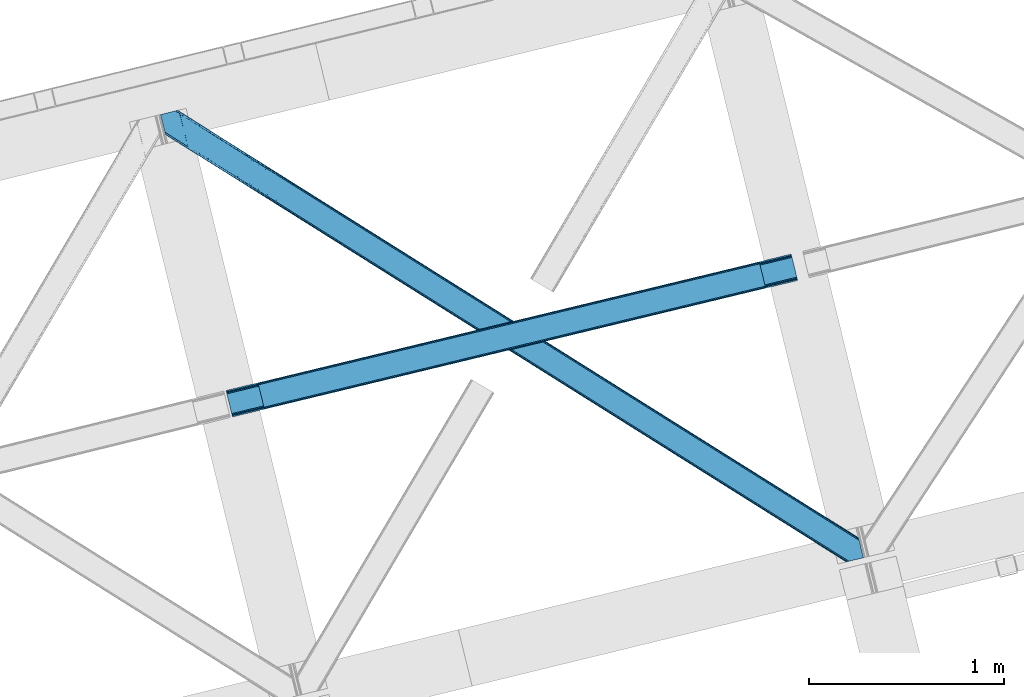
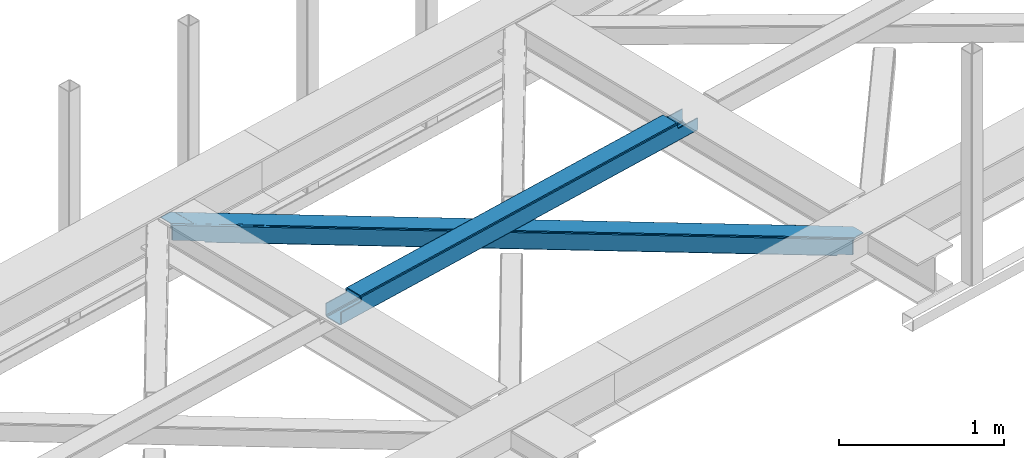
# One storey, part 24 of 67: 1 beam, 1 member.
"""IFC4 building model written with IfcOpenShell, lengths in millimetres."""

from ifc_helpers import new_model, entity, si_unit, converted_unit, derived_unit, direction, frame, origin, place, context, subcontext, project, spatial, triangles, polygons, material, type_object, element, save


model = new_model("IFC4")

# Units and contexts
model_context = context("Model", 3, precision=0.01, world=origin(), true_north=direction((6.12303176911189e-17, 1.0)))
plan_context = context("Plan", 3, precision=0.01, world=origin(), true_north=direction((6.12303176911189e-17, 1.0)))
body_context = subcontext(model_context, "Body", "Model", "MODEL_VIEW")
ifc_project = project(units=[si_unit("LENGTHUNIT", "METRE", prefix="MILLI"), si_unit("AREAUNIT", "SQUARE_METRE"), si_unit("VOLUMEUNIT", "CUBIC_METRE"), converted_unit("PLANEANGLEUNIT", "DEGREE", entity("IfcRatioMeasure", 0.0174532925199433), si_unit("PLANEANGLEUNIT", "RADIAN"), dimensions=[0, 0, 0, 0, 0, 0, 0]), si_unit("MASSUNIT", "GRAM", prefix="KILO"), derived_unit("MASSDENSITYUNIT", [(si_unit("MASSUNIT", "GRAM", prefix="KILO"), 1), (si_unit("LENGTHUNIT", "METRE"), -3)]), derived_unit("MOMENTOFINERTIAUNIT", [(si_unit("LENGTHUNIT", "METRE"), 4)]), si_unit("TIMEUNIT", "SECOND"), si_unit("FREQUENCYUNIT", "HERTZ"), si_unit("THERMODYNAMICTEMPERATUREUNIT", "DEGREE_CELSIUS"), derived_unit("THERMALTRANSMITTANCEUNIT", [(si_unit("MASSUNIT", "GRAM", prefix="KILO"), 1), (si_unit("THERMODYNAMICTEMPERATUREUNIT", "KELVIN"), -1), (si_unit("TIMEUNIT", "SECOND"), -3)]), derived_unit("VOLUMETRICFLOWRATEUNIT", [(si_unit("LENGTHUNIT", "METRE"), 3), (si_unit("TIMEUNIT", "SECOND"), -1)]), derived_unit("MASSFLOWRATEUNIT", [(si_unit("MASSUNIT", "GRAM", prefix="KILO"), 1), (si_unit("TIMEUNIT", "SECOND"), -1)]), derived_unit("ROTATIONALFREQUENCYUNIT", [(si_unit("TIMEUNIT", "SECOND"), -1)]), si_unit("ELECTRICCURRENTUNIT", "AMPERE"), si_unit("ELECTRICVOLTAGEUNIT", "VOLT"), si_unit("POWERUNIT", "WATT"), si_unit("FORCEUNIT", "NEWTON", prefix="KILO"), si_unit("ILLUMINANCEUNIT", "LUX"), si_unit("LUMINOUSFLUXUNIT", "LUMEN"), si_unit("LUMINOUSINTENSITYUNIT", "CANDELA"), derived_unit("USERDEFINED", [(si_unit("MASSUNIT", "GRAM", prefix="KILO"), -1), (si_unit("LENGTHUNIT", "METRE"), -2), (si_unit("TIMEUNIT", "SECOND"), 3), (si_unit("LUMINOUSFLUXUNIT", "LUMEN"), 1)]), derived_unit("LINEARVELOCITYUNIT", [(si_unit("LENGTHUNIT", "METRE"), 1), (si_unit("TIMEUNIT", "SECOND"), -1)]), si_unit("PRESSUREUNIT", "PASCAL"), derived_unit("USERDEFINED", [(si_unit("LENGTHUNIT", "METRE"), -2), (si_unit("MASSUNIT", "GRAM", prefix="KILO"), 1), (si_unit("TIMEUNIT", "SECOND"), -2)]), derived_unit("LINEARFORCEUNIT", [(si_unit("MASSUNIT", "GRAM", prefix="KILO"), 1), (si_unit("LENGTHUNIT", "METRE"), 1), (si_unit("TIMEUNIT", "SECOND"), -2), (si_unit("LENGTHUNIT", "METRE"), -1)]), derived_unit("PLANARFORCEUNIT", [(si_unit("MASSUNIT", "GRAM", prefix="KILO"), 1), (si_unit("LENGTHUNIT", "METRE"), 1), (si_unit("TIMEUNIT", "SECOND"), -2), (si_unit("LENGTHUNIT", "METRE"), -2)])], contexts=[model_context, plan_context])

# Site, building, storey
site_placement = place(None, origin())
site = spatial("IfcSite", under=ifc_project, at=site_placement, CompositionType="ELEMENT")
building_placement = place(site_placement, origin())
building = spatial("IfcBuilding", under=site, at=building_placement, CompositionType="ELEMENT")
storey_placement = place(building_placement, frame((0.0, 0.0, 19800.0)))
storey = spatial("IfcBuildingStorey", under=building, at=storey_placement, CompositionType="ELEMENT", Elevation=19800.0)

# Beam
ifc_material = material(Name="Metal painted (White)")
beam_type = type_object("IfcBeamType", PredefinedType="BEAM")
beam_placement = place(storey_placement, frame((-51911.0997216183, 6486.04890050032, 3967.02210387248)))
element("IfcBeam", 1, at=beam_placement, inside=storey, type_object=beam_type, material=ifc_material, ObjectType="Steel Beam", PredefinedType="BEAM", context=body_context, shape_type="Tessellation", body=[
    polygons([(195.778682216866, 46.4616874765742, 115.554291398401), (195.463203470787, 47.7559030808816, 122.251250865174), (2771.46289360968, 669.656122833178, 123.101189027514), (2771.77837235578, 668.361907228809, 116.404229560714), (194.564796011733, 51.4415173004408, 127.928657073123), (2770.56448615062, 673.341737052787, 128.778595235445), (193.220234231301, 56.9574287804367, 131.722176392876), (2769.21992437018, 678.85764853278, 132.572114555207), (191.634215472016, 63.4638900000246, 133.054279896355), (2767.63390561093, 685.364109752213, 133.904218058669), (170.082988398813, 151.875343121848, 133.054215405194), (2746.08267853773, 773.775562874038, 133.904153567521), (168.496969639606, 158.381804341166, 131.72210240954), (2744.49665977849, 780.28202409347, 132.572040571853), (167.152407859165, 163.897715821159, 127.928575042685), (2743.15209799806, 785.797935573463, 128.778513205003), (166.254000400103, 167.583330040754, 122.251163457846), (2742.25369053899, 789.483549793037, 123.101101620168), (165.938521653972, 168.877545645258, 115.554202102942), (2741.93821179289, 790.777765397476, 116.404140265269), (2740.28042509495, 797.578646406835, 101.477896127514), (2740.28042509495, 797.578646406844, 123.40413566445), (2740.59590384104, 796.284430802519, 130.101097019346), (2741.49431130009, 792.598816582945, 135.778508604176), (2742.83887308054, 787.082905102956, 139.572035971027), (2744.4248918398, 780.576443883409, 140.904148966698), (2769.29169230888, 678.563228742844, 140.904223379569), (2770.87771106808, 672.056767523566, 139.572119876094), (2772.22227284852, 666.540856043575, 135.778600556341), (2773.12068030758, 662.855241823993, 130.101194348401), (2773.43615905372, 661.561026219421, 123.404234881614), (2773.43615905373, 661.561026219411, 101.477896127514), (2771.77837235579, 668.361907228782, 101.477896127514), (2741.9382117929, 790.777765397463, 101.477896127514), (165.938521653972, 168.877545645274, 100.498120018943), (195.778682216866, 46.4616874765926, 100.498120018943), (197.436468914803, 39.6608064672213, 100.498120018943), (197.436468914803, 39.6608064672115, 122.554296719296), (197.120990168698, 40.9550220716445, 129.251256186074), (196.222582709644, 44.6406362912287, 134.928662394019), (194.878020929195, 50.1565477712202, 138.722181713772), (193.292002169953, 56.6630089906522, 140.054285217251), (168.425201700885, 158.676224131221, 140.054210804376), (166.839182941635, 165.182685350655, 138.722097808709), (165.494621161203, 170.698596830647, 134.928570441863), (164.59621370214, 174.384211050237, 129.251158857028), (164.280734956026, 175.67842665464, 122.554197502128), (164.280734956035, 175.678426654645, 100.498120018943), (2936.05910731181, 708.022713695996, 100.477896127497), (2936.0591073118, 708.022713695992, 25.4584284837512), (31.4979472608401, 6.80088100936265, 24.5000831143001), (31.4979472608314, 6.80088100937781, 99.4981200189255), (194.806606862087, 46.2270081483837, 99.4981200189385), (1.657786697954, 129.216739178047, 24.4999938188589), (2906.21894674892, 830.438571864674, 25.4583391883013), (2906.21894674892, 830.438571864675, 100.477896127506), (2742.91028714767, 791.012444725669, 100.477896127515), (1.65778669794533, 129.216739178059, 99.4981200189342), (2937.71689400975, 701.221832686621, 18.4584330845693), (2937.71689400975, 701.221832686624, 100.477896127497), (2774.40823440849, 661.795705547618, 100.477896127515), (33.1557339587681, 6.49720277579036e-12, 99.4981200189298), (33.1557339587768, 4.33146851719357e-12, 17.5000877151226), (2904.56116005097, 837.239452874047, 100.477896127506), (2904.56116005097, 837.239452874045, 18.4583338674014), (0.0, 136.017620187427, 17.499988497959), (0.0, 136.017620187429, 99.4981200189342), (163.308659601255, 175.443747326438, 99.4981200189428), (2772.75044771055, 668.596586556989, 100.477896127506), (2741.25250044972, 797.81332573504, 100.47789612751), (2906.53442549502, 829.144356260237, 18.7613797215148), (2907.43283295407, 825.458742040662, 13.0839735135745), (2908.77739473452, 819.942830560673, 9.29045419381724), (2910.36341349377, 813.436369341239, 7.95835069034235), (2931.91464056696, 725.024916219415, 7.95841518150347), (2933.50065932619, 718.518454999981, 9.29052817716638), (2934.84522110663, 713.002543519989, 13.0840555440168), (2935.7436285657, 709.316929300409, 18.7614671288472), (2937.40141526367, 702.516048290886, 11.761471729687), (2936.50300780461, 706.20166251046, 6.08406014484364), (2935.15844602418, 711.717573990453, 2.29053277800185), (2933.5724272649, 718.224035210042, 0.958419782317287), (2908.70562679582, 820.237250350608, 0.958345369446738), (2907.1196080366, 826.743711569928, 2.29044887293462), (2905.77504625616, 832.259623049922, 6.0839681926919), (2904.87663879711, 835.945237269508, 11.7613744006322), (196.464393560023, 39.4261271390135, 99.4981200189342), (164.966446299201, 168.642866317066, 99.4981200189385), (27.3534805159897, 23.803083532798, 7.00006981205673), (28.9394992752661, 17.2966223132111, 8.33218280774563), (30.2840610557156, 11.7807108332185, 12.1257101745917), (31.1824685147694, 8.09509661364405, 17.8031217594308), (1.97326544407667, 127.922523573537, 17.8030343520854), (2.87167290313907, 124.236909353931, 12.1256281441494), (4.21623468357996, 118.72099787394, 8.33210882439216), (5.80225344279568, 112.214536654621, 7.00000532091294), (0.315478746122676, 134.723404583003, 10.8030290311768), (1.21388620517641, 131.037790363419, 5.12562282323216), (2.5584479856173, 125.521878883426, 1.33210350348355), (4.14446674485034, 119.015417663994, 0.0), (29.0112672139351, 17.0022025234256, 7.44128792121046e-05), (30.5972859731681, 10.4957413039946, 1.33218740854212), (31.9418477536177, 4.97982982400309, 5.12571477538823), (32.8402552126714, 1.29421560440701, 10.803126360223)], [[[1, 2, 3, 4]], [[2, 5, 6, 3]], [[5, 7, 8, 6]], [[7, 9, 10, 8]], [[11, 12, 10, 9]], [[11, 13, 14, 12]], [[13, 15, 16, 14]], [[15, 17, 18, 16]], [[17, 19, 20, 18]], [[21, 22, 23, 24, 25, 26, 27, 28, 29, 30, 31, 32, 33, 4, 3, 6, 8, 10, 12, 14, 16, 18, 20, 34]], [[35, 19, 17, 15, 13, 11, 9, 7, 5, 2, 1, 36, 37, 38, 39, 40, 41, 42, 43, 44, 45, 46, 47, 48]], [[42, 41, 28, 27]], [[41, 40, 29, 28]], [[40, 39, 30, 29]], [[39, 38, 31, 30]], [[27, 26, 43, 42]], [[47, 46, 23, 22]], [[46, 45, 24, 23]], [[45, 44, 25, 24]], [[44, 43, 26, 25]], [[33, 49, 50, 51, 52, 53, 1, 4]], [[54, 55, 56, 57, 20, 19, 35, 58]], [[59, 60, 61, 31, 38, 37, 62, 63]], [[64, 65, 66, 67, 68, 47, 22, 21]], [[61, 60, 49, 69]], [[64, 70, 57, 56]], [[65, 64, 56, 55, 71, 72, 73, 74, 75, 76, 77, 78, 50, 49, 60, 59, 79, 80, 81, 82, 83, 84, 85, 86]], [[87, 53, 52, 62]], [[67, 58, 88, 68]], [[89, 90, 76, 75]], [[90, 91, 77, 76]], [[91, 92, 78, 77]], [[92, 51, 50, 78]], [[54, 93, 71, 55]], [[93, 94, 72, 71]], [[94, 95, 73, 72]], [[95, 96, 74, 73]], [[89, 75, 74, 96]], [[66, 97, 98, 99, 100, 101, 102, 103, 104, 63, 62, 52, 51, 92, 91, 90, 89, 96, 95, 94, 93, 54, 58, 67]], [[63, 104, 79, 59]], [[104, 103, 80, 79]], [[103, 102, 81, 80]], [[102, 101, 82, 81]], [[100, 99, 84, 83]], [[99, 98, 85, 84]], [[98, 97, 86, 85]], [[97, 66, 65, 86]], [[83, 82, 101, 100]]], closed=False),
])

# Member
member_type = type_object("IfcMemberType", PredefinedType="BRACE")
member_placement = place(storey_placement, frame((-52247.5317993164, 5740.77633361816, 3823.99987792968)))
element("IfcMember", 2, at=member_placement, inside=storey, type_object=member_type, ObjectType="Steel Horizontal Brace", PredefinedType="BRACE", context=body_context, shape_type="Tessellation", body=[
    triangles([(207.717553710936, 2101.81589355469, 0.0), (172.040661621089, 2248.17905273438, 0.0), (3404.48986816406, 219.29300994873, 0.0), (3440.1667602539, 72.9298507690428, 0.0), (202.587634277341, 2097.1307144165, 1.33247680664135), (208.508203124999, 2098.57423095703, 0.155804443358647), (3442.44104003906, 63.5949554443359, 1.33247680664135), (3445.65944824219, 50.3934356689451, 10.8039916992202), (3446.115234375, 48.5365722656252, 17.5012573242202), (187.946667480464, 2093.56290893555, 17.5012573242202), (189.755859375, 2094.00241699219, 10.8039916992202), (3444.37115478516, 55.6809036254881, 5.12526855468968), (194.895080566406, 2095.25582885742, 5.12526855468968), (3405.08983154297, 238.005239868164, 10.8039916992202), (3400.22036132812, 236.818103027344, 5.32758178711083), (167.836267089842, 2265.42799987793, 5.12526855468968), (166.547973632813, 2270.71546783447, 10.8039916992202), (3400.29477539063, 236.497192382813, 5.1694519042976), (3402.2155883789, 228.627905273437, 1.33247680664135), (169.766381835936, 2257.51394805908, 1.33247680664135), (3406.89437255859, 238.445329284668, 17.5012573242202), (166.092187499999, 2272.57233123779, 17.5012573242202), (3401.18774414063, 237.054716491699, 18.5197998046897), (3406.89437255859, 238.445329284668, 18.5197998046897), (3400.50406494141, 236.887284851075, 18.2267944335945), (3400.82032470703, 236.964024353028, 18.4453857421868), (3400.29012451172, 236.836125183106, 17.9035583496116), (3400.22036132812, 236.818103027344, 17.5198608398459), (3402.03885498047, 231.950958251953, 18.4453857421868), (3401.8388671875, 231.936424255371, 18.1454040527351), (3401.62027587891, 231.919564819336, 17.8198425292976), (3401.61097412109, 231.919564819336, 17.8058898925774), (3401.41563720703, 231.905030822754, 17.5198608398459), (3402.49464111328, 231.698066711426, 18.5197998046897), (3586.90198974609, 125.462109375, 18.5197998046897), (3589.63670654297, 114.236050415039, 18.5197998046897), (204.378222656247, 2097.56731567383, 12.1248413085959), (208.508203124999, 2098.57423095703, 9.69243164062573), (199.648278808592, 2096.41447906494, 17.9802978515618), (198.420446777345, 2096.11566009522, 19.5011352539077), (187.946667480464, 2093.56290893555, 19.5011352539077), (25.3054321289019, 2195.64679412842, 19.5011352539077), (22.6823364257798, 2206.42113647461, 19.5011352539077), (3437.79016113281, 82.6873947143558, 6.99957275390625), (3404.5921875, 218.870361328125, 8.3320495605476), (3402.6620727539, 226.784413146973, 12.1248413085959), (3406.86646728515, 209.535466003418, 6.99957275390625), (3443.24099121094, 60.3178298950197, 17.5198608398459), (3441.99455566406, 65.4384475708011, 12.1248413085959), (3446.115234375, 48.5365722656252, 17.5198608398459), (3440.06444091797, 73.3524993896481, 8.3320495605476), (1232.85963134765, 1574.07833862305, 6.99957275390625), (640.584155273435, 1945.82715911865, 6.99957275390625), (602.800415039063, 1862.10203704834, 6.99957275390625), (1195.07589111328, 1490.35496063232, 6.99957275390625), (1825.13510742188, 1202.32893676758, 6.99957275390625), (1787.3467163086, 1118.60730285645, 6.99957275390625), (205.340954589839, 2111.5734375, 6.99957275390625), (174.417260742186, 2238.42150878906, 6.99957275390625), (2971.89301757812, 375.112568664551, 6.99957275390625), (3009.68605957031, 458.831295776367, 6.99957275390625), (2379.62219238281, 746.86022644043, 6.99957275390625), (2417.41058349609, 830.580116271973, 6.99957275390625), (168.831555175777, 2261.33638916016, 18.501196289064), (166.092187499999, 2272.57233123779, 18.501196289064), (168.966430664063, 2260.78526000977, 17.8803039550803), (170.212866210939, 2255.67045593262, 12.1248413085959), (172.142980957033, 2247.75640411377, 8.3320495605476), (207.559423828126, 2102.47631835938, 8.8831787109375), (3444.59439697266, 58.9993057250977, 18.5197998046897), (3447.32911376953, 47.7738281250004, 18.5197998046897), (3447.04075927734, 47.9540496826176, 18.2849304199226), (3444.26883544922, 59.3173095703123, 18.2802795410171), (3446.71984863281, 48.1552001953123, 18.0198303222678), (3443.91536865234, 59.6585678100582, 18.0198303222678), (3446.39893798828, 48.3557693481443, 17.757055664064), (3443.62701416016, 59.9416900634769, 17.8058898925774), (3443.56655273437, 60.0004074096678, 17.7617065429695), (3534.35635986328, 2.65972137451172, 18.5197998046897), (3523.44074707031, 0.0, 18.5197998046897), (2962.59125976562, 360.290217590332, 24.5008300781265), (2963.29819335938, 361.418637084961, 17.8035644531265), (3532.92854003906, 2.31148681640661, 24.5008300781265), (2965.31667480469, 364.631813049316, 12.1248413085959), (596.224072265621, 1851.62128143311, 12.1248413085959), (599.242492675781, 1856.42970886231, 8.3320495605476), (594.205590820311, 1848.40810546875, 17.8035644531265), (593.498657226563, 1847.28026733398, 24.5008300781265), (22.9288330078125, 2205.40433807373, 24.5008300781265), (2968.33509521484, 369.440240478516, 8.3320495605476), (2370.3157836914, 732.037875366211, 24.5008300781265), (2371.02271728515, 733.165713500976, 17.8035644531265), (1778.0449584961, 1103.78495178223, 24.5008300781265), (1778.75189208984, 1104.91337127686, 17.8035644531265), (1185.76948242187, 1475.53260955811, 24.5008300781265), (1186.47641601563, 1476.66102905273, 17.8035644531265), (2373.04119873047, 736.379470825195, 12.1248413085959), (1780.77037353515, 1108.12654724121, 12.1248413085959), (1188.49489746094, 1479.87420501709, 12.1248413085959), (2376.05961914062, 741.187898254395, 8.3320495605476), (1783.78879394531, 1112.93555603027, 8.3320495605476), (1191.51331787109, 1484.68263244629, 8.3320495605476), (2965.14924316406, 350.42105255127, 122.499499511719), (2371.32037353516, 723.143650817871, 122.499499511719), (3523.44074707031, 0.0, 122.499499511719), (1777.49615478516, 1095.86624908447, 122.499499511719), (1183.66728515625, 1468.58826599121, 122.499499511719), (589.838415527345, 1841.31144561768, 122.499499511719), (25.3054321289019, 2195.64679412842, 122.499499511719), (3532.92854003906, 2.31148681640661, 115.499926757813), (22.9288330078125, 2205.40433807373, 115.499926757813), (3534.73308105468, 2.75157623291034, 122.197192382813), (22.4776977539077, 2207.26120147705, 122.197192382813), (3539.87230224609, 4.00440673828143, 127.873590087893), (21.1847534179688, 2212.54866943359, 127.873590087893), (3547.56485595703, 5.87929229736346, 131.668707275392), (19.2592895507769, 2220.46272125244, 131.668707275392), (3556.63872070312, 8.09136657714862, 133.001184082033), (16.9803588867144, 2229.79819793701, 133.001184082033), (3525.24993896484, 0.439508056640989, 129.196765136719), (3530.38916015625, 1.69291992187482, 134.87548828125), (3547.15092773437, 5.77929840087927, 140.00075683594), (3612.207421875, 21.6376327514645, 140.00075683594), (3612.207421875, 21.6376327514645, 133.001184082033), (3538.08171386718, 3.56780548095685, 138.668280029298), (168.515295410158, 2261.63055725098, 18.7407165527366), (165.808483886714, 2272.75313415527, 18.7360656738274), (168.171130371091, 2261.94856109619, 19.0011657714858), (165.487573242186, 2272.95428466797, 19.0011657714858), (167.822314453122, 2262.26656494141, 19.2592895507805), (165.166662597658, 2273.1548538208, 19.2639404296897), (167.506054687496, 2262.56073303223, 19.5011352539077), (164.878308105464, 2273.33565673828, 19.5011352539077), (78.2928955078096, 2318.55673370361, 19.5011352539077), (88.7666748046831, 2321.10948486328, 19.5011352539077), (649.178979492186, 1959.52109069824, 17.8035644531265), (3018.28088378906, 472.524645996094, 17.8035644531265), (3016.26705322265, 469.312051391602, 12.1248413085959), (3018.99246826172, 473.653065490723, 24.5008300781265), (3589.27858886719, 115.704565429687, 24.5008300781265), (649.885913085935, 1960.64951019287, 24.5008300781265), (79.2788818359331, 2318.79741668701, 24.5008300781265), (3013.2486328125, 464.503042602539, 8.3320495605476), (644.142077636716, 1951.49948730469, 8.3320495605476), (647.160498046876, 1956.30849609375, 12.1248413085959), (2420.97315673828, 836.252444458008, 8.3320495605476), (1828.69768066406, 1208.00126495361, 8.3320495605476), (1236.41755371093, 1579.75066680908, 8.3320495605476), (2423.99157714844, 841.060871887207, 12.1248413085959), (1831.71610107422, 1212.81027374268, 12.1248413085959), (1239.440625, 1584.55909423828, 12.1248413085959), (2426.00540771485, 844.274047851563, 17.8035644531265), (1833.72993164062, 1216.02344970703, 17.8035644531265), (1241.4544555664, 1587.77227020264, 17.8035644531265), (2426.7169921875, 845.402467346192, 24.5008300781265), (1834.43686523438, 1217.1512878418, 24.5008300781265), (1242.16138916015, 1588.90068969727, 24.5008300781265), (1247.70523681641, 1593.6864440918, 122.499499511719), (653.811254882814, 1966.45031890869, 122.499499511719), (1841.59921875, 1220.9225692749, 122.499499511719), (3586.90198974609, 125.462109375, 122.499499511719), (2435.4932006836, 848.158113098145, 122.499499511719), (3029.38253173828, 475.39423828125, 122.499499511719), (88.7666748046831, 2321.10948486328, 122.499499511719), (3591.02266845703, 108.559652709961, 127.873590087893), (3588.64141845703, 118.317196655274, 134.87548828125), (3590.57153320313, 110.403144836426, 138.668280029298), (3592.94813232421, 100.646182250976, 131.668707275392), (3595.22706298828, 91.3107055664059, 133.001184082033), (3592.84581298828, 101.068249511719, 140.00075683594), (3589.72972412109, 113.847702026367, 122.197192382813), (3587.353125, 123.605245971679, 129.196765136719), (3589.27858886719, 115.704565429687, 115.499926757813), (55.5687011718765, 2313.01753692627, 133.001184082033), (0.0, 2299.47127075195, 133.001184082033), (79.2788818359331, 2318.79741668701, 115.499926757813), (64.6425659179658, 2315.22961120605, 131.668707275392), (72.3351196289077, 2317.10449676514, 127.873590087893), (77.474340820314, 2318.35732727051, 122.197192382813), (86.962133789064, 2320.66939544678, 129.196765136719), (81.8182617187485, 2319.41656494141, 134.87548828125), (76.0604736328096, 2318.01258087158, 138.000878906252), (0.0, 2299.47127075195, 138.000878906252), (24.8542968749971, 2197.50365753174, 129.196765136719), (23.5660034179673, 2202.79170684814, 134.87548828125), (22.1195800781206, 2208.71634521484, 138.000878906252), (98.1893554687485, 2304.12331237793, 138.000878906252), (139.386840820313, 2135.11211700439, 138.000878906252), (599.144824218747, 1856.13321533203, 140.00075683594), (139.824023437497, 2137.54568939209, 139.000817871096), (140.051916503908, 2136.3818069458, 138.668280029298), (137.842749023439, 2145.67368164063, 140.00075683594), (592.563830566403, 1845.6524597168, 134.87548828125), (139.805419921875, 2135.0249130249, 138.075292968751), (595.582250976564, 1850.460887146, 138.668280029298), (139.917041015622, 2135.65917663574, 138.352020263672), (140.033312988278, 2136.29576568604, 138.631072998047), (2974.45100097656, 365.243403625488, 140.00075683594), (2970.88842773438, 359.570494079589, 138.668280029298), (2967.87000732421, 354.762066650391, 134.87548828125), (2965.85617675781, 351.548890686036, 129.196765136719), (590.549999999996, 1842.43928375244, 129.196765136719), (2372.0273071289, 724.271488952637, 129.196765136719), (1778.2030883789, 1096.99408721924, 129.196765136719), (1184.37421875, 1469.71668548584, 129.196765136719), (2374.04578857421, 727.484664916992, 134.87548828125), (1780.21691894531, 1100.20726318359, 134.87548828125), (1186.39270019531, 1472.92986145019, 134.87548828125), (2377.06420898438, 732.293092346192, 138.668280029298), (1783.23533935547, 1105.01627197266, 138.668280029298), (1189.41112060547, 1477.73828887939, 138.668280029298), (2380.62213134766, 737.965420532227, 140.00075683594), (1786.79791259766, 1110.68801879883, 140.00075683594), (1192.96904296875, 1483.41061706543, 140.00075683594), (651.085839843749, 1962.10930480957, 134.87548828125), (98.7056030273452, 2303.62683105469, 138.075292968751), (99.1985961914033, 2302.47515716553, 138.384576416018), (648.067419433595, 1957.30029602051, 138.668280029298), (99.5985717773438, 2301.53742370606, 138.633398437501), (644.509497070314, 1951.62796783447, 140.00075683594), (100.184582519527, 2300.16425170898, 139.000817871096), (102.165856933592, 2292.03625946045, 140.00075683594), (3028.67559814453, 474.265818786621, 129.196765136719), (3026.65711669921, 471.052642822266, 134.87548828125), (3023.64334716797, 466.244215393066, 138.668280029298), (3020.08077392578, 460.571887207031, 140.00075683594), (653.104321289058, 1965.32189941406, 129.196765136719), (2426.18679199219, 833.335762023926, 140.00075683594), (2429.74936523438, 839.008090209961, 138.668280029298), (1832.2974609375, 1206.10021820068, 140.00075683594), (1835.85538330078, 1211.77196502686, 138.668280029298), (1238.40347900391, 1578.86409301758, 140.00075683594), (1241.96140136719, 1584.53642120361, 138.668280029298), (2432.76778564453, 843.817098999023, 134.87548828125), (1838.87380371094, 1216.58097381592, 134.87548828125), (1244.97982177734, 1589.34484863281, 134.87548828125), (2434.78161621094, 847.030274963379, 129.196765136719), (1840.89228515625, 1219.79414978027, 129.196765136719), (1246.99830322265, 1592.55802459717, 129.196765136719)], [[1, 2, 3], [3, 4, 1], [5, 6, 4], [4, 7, 5], [8, 9, 10], [10, 11, 8], [12, 8, 11], [11, 13, 12], [7, 12, 13], [13, 5, 7], [6, 1, 4], [14, 15, 16], [16, 17, 14], [18, 19, 20], [19, 3, 2], [2, 20, 19], [20, 16, 18], [15, 18, 16], [21, 14, 17], [17, 22, 21], [23, 21, 24], [25, 23, 26], [23, 25, 27], [23, 27, 28], [21, 23, 28], [28, 15, 14], [14, 21, 28], [26, 29, 30], [25, 30, 31], [27, 32, 33], [27, 31, 32], [33, 28, 27], [31, 27, 25], [30, 25, 26], [23, 34, 29], [29, 26, 23], [34, 24, 35], [24, 34, 23], [35, 36, 34], [37, 38, 5], [37, 5, 13], [13, 11, 39], [38, 6, 5], [39, 37, 13], [11, 10, 40], [41, 40, 10], [11, 40, 39], [42, 43, 40], [40, 41, 42], [3, 44, 4], [45, 19, 46], [33, 15, 28], [18, 33, 46], [33, 18, 15], [3, 19, 45], [46, 19, 18], [3, 47, 44], [45, 47, 3], [8, 48, 9], [48, 12, 49], [12, 48, 8], [50, 9, 48], [49, 7, 51], [51, 4, 44], [4, 51, 7], [49, 12, 7], [52, 53, 54], [54, 55, 52], [55, 56, 52], [56, 55, 57], [53, 58, 54], [53, 59, 58], [60, 61, 62], [61, 60, 47], [44, 47, 60], [63, 62, 61], [57, 63, 56], [62, 63, 57], [17, 22, 64], [22, 65, 64], [66, 17, 64], [66, 16, 17], [67, 16, 66], [20, 67, 68], [67, 20, 16], [2, 20, 68], [68, 59, 2], [69, 38, 6], [69, 1, 58], [1, 59, 58], [59, 1, 2], [69, 6, 1], [70, 71, 72], [72, 73, 70], [73, 72, 74], [74, 75, 73], [75, 76, 77], [75, 74, 76], [76, 78, 77], [78, 76, 50], [50, 48, 78], [71, 70, 79], [79, 80, 71], [81, 70, 73], [73, 82, 81], [73, 75, 82], [75, 77, 82], [83, 79, 70], [70, 81, 83], [82, 77, 78], [78, 84, 82], [78, 48, 84], [48, 49, 84], [54, 58, 69], [85, 86, 38], [86, 69, 38], [87, 85, 37], [88, 87, 39], [39, 40, 88], [88, 40, 89], [43, 89, 40], [37, 39, 87], [38, 37, 85], [69, 86, 54], [51, 44, 90], [60, 90, 44], [49, 51, 84], [90, 84, 51], [81, 82, 91], [92, 91, 82], [91, 92, 93], [94, 93, 92], [93, 94, 95], [96, 95, 94], [95, 96, 87], [87, 88, 95], [82, 84, 97], [97, 92, 82], [92, 97, 98], [98, 94, 92], [94, 98, 99], [99, 96, 94], [96, 99, 85], [85, 87, 96], [84, 90, 100], [100, 97, 84], [97, 100, 101], [101, 98, 97], [98, 101, 102], [102, 99, 98], [99, 102, 86], [86, 85, 99], [90, 60, 100], [62, 100, 60], [100, 62, 57], [57, 101, 100], [101, 57, 55], [55, 102, 101], [102, 55, 54], [54, 86, 102], [9, 103, 104], [71, 105, 72], [71, 80, 105], [105, 74, 72], [50, 105, 103], [50, 76, 105], [76, 74, 105], [9, 50, 103], [106, 10, 9], [10, 107, 108], [109, 41, 108], [106, 107, 10], [106, 9, 104], [10, 108, 41], [42, 41, 109], [81, 110, 83], [110, 81, 91], [110, 93, 111], [93, 110, 91], [88, 89, 111], [95, 111, 93], [111, 95, 88], [112, 110, 111], [111, 113, 112], [114, 112, 113], [113, 115, 114], [116, 114, 115], [115, 117, 116], [118, 116, 117], [117, 119, 118], [112, 120, 121], [118, 122, 123], [123, 124, 118], [118, 116, 122], [116, 125, 122], [114, 125, 116], [121, 125, 114], [112, 105, 120], [110, 105, 112], [121, 114, 112], [80, 83, 79], [110, 80, 105], [83, 80, 110], [65, 64, 126], [126, 127, 65], [127, 126, 128], [128, 129, 127], [129, 128, 130], [130, 131, 129], [131, 130, 132], [132, 133, 131], [134, 135, 133], [133, 132, 134], [136, 66, 67], [137, 138, 33], [138, 46, 33], [139, 29, 34], [34, 140, 139], [34, 36, 140], [139, 137, 32], [32, 31, 139], [30, 29, 139], [139, 31, 30], [141, 130, 128], [141, 132, 130], [128, 136, 141], [64, 136, 126], [128, 126, 136], [64, 66, 136], [132, 141, 142], [142, 134, 132], [33, 32, 137], [45, 46, 143], [138, 143, 46], [47, 45, 61], [143, 61, 45], [53, 144, 59], [68, 59, 144], [144, 145, 68], [67, 68, 145], [67, 145, 136], [61, 143, 63], [146, 63, 143], [63, 146, 147], [147, 56, 63], [56, 147, 148], [148, 52, 56], [52, 148, 144], [144, 53, 52], [143, 138, 146], [149, 146, 138], [146, 149, 147], [150, 147, 149], [147, 150, 148], [151, 148, 150], [148, 151, 144], [145, 144, 151], [138, 137, 152], [152, 149, 138], [149, 152, 153], [153, 150, 149], [150, 153, 154], [154, 151, 150], [151, 154, 136], [136, 145, 151], [137, 139, 152], [155, 152, 139], [152, 155, 153], [156, 153, 155], [153, 156, 154], [157, 154, 156], [154, 157, 136], [141, 136, 157], [158, 22, 159], [22, 158, 160], [161, 35, 24], [21, 160, 162], [21, 163, 24], [160, 21, 22], [24, 163, 161], [162, 163, 21], [164, 159, 65], [164, 65, 127], [22, 65, 159], [129, 164, 127], [164, 129, 131], [131, 133, 164], [135, 164, 133], [165, 166, 167], [165, 167, 168], [169, 168, 170], [171, 166, 165], [124, 169, 123], [170, 123, 169], [168, 167, 170], [172, 166, 171], [35, 161, 173], [140, 35, 173], [35, 140, 36], [172, 171, 161], [171, 173, 161], [119, 174, 169], [174, 119, 175], [169, 118, 119], [124, 118, 169], [156, 173, 176], [173, 155, 139], [156, 155, 173], [139, 140, 173], [157, 176, 141], [176, 157, 156], [142, 141, 176], [168, 169, 174], [174, 177, 168], [165, 168, 177], [177, 178, 165], [171, 165, 178], [178, 179, 171], [173, 171, 179], [179, 176, 173], [179, 180, 181], [174, 182, 183], [183, 175, 174], [174, 177, 182], [178, 182, 177], [181, 182, 178], [179, 164, 180], [176, 164, 179], [181, 178, 179], [135, 142, 134], [176, 135, 164], [142, 135, 176], [111, 42, 109], [184, 113, 109], [113, 184, 185], [113, 111, 109], [89, 42, 111], [43, 42, 89], [115, 113, 185], [186, 119, 117], [119, 186, 183], [183, 175, 119], [117, 115, 186], [186, 115, 185], [182, 186, 187], [182, 183, 186], [188, 187, 186], [189, 190, 191], [189, 192, 190], [193, 194, 188], [188, 185, 193], [188, 186, 185], [195, 196, 194], [195, 191, 196], [194, 193, 195], [197, 195, 189], [125, 122, 198], [198, 199, 125], [121, 125, 199], [199, 200, 121], [120, 121, 200], [200, 201, 120], [105, 120, 201], [201, 103, 105], [108, 202, 109], [184, 109, 202], [202, 193, 184], [185, 184, 193], [103, 201, 104], [203, 104, 201], [104, 203, 204], [204, 106, 104], [106, 204, 205], [205, 107, 106], [107, 205, 108], [202, 108, 205], [201, 200, 203], [206, 203, 200], [203, 206, 204], [207, 204, 206], [204, 207, 208], [208, 205, 204], [205, 208, 193], [193, 202, 205], [200, 199, 209], [209, 206, 200], [206, 209, 210], [210, 207, 206], [207, 210, 208], [211, 208, 210], [208, 211, 193], [195, 193, 211], [199, 198, 212], [212, 209, 199], [209, 212, 213], [213, 210, 209], [210, 213, 214], [214, 211, 210], [211, 214, 189], [189, 195, 211], [215, 216, 217], [217, 218, 215], [217, 219, 218], [187, 215, 181], [181, 182, 187], [219, 220, 218], [219, 221, 220], [221, 222, 220], [172, 161, 223], [163, 223, 161], [166, 172, 224], [223, 224, 172], [167, 166, 225], [224, 225, 166], [170, 167, 226], [225, 226, 167], [215, 227, 180], [180, 181, 215], [227, 159, 164], [164, 180, 227], [226, 225, 228], [229, 228, 225], [228, 229, 230], [231, 230, 229], [230, 231, 232], [233, 232, 231], [232, 233, 220], [218, 220, 233], [225, 224, 234], [234, 229, 225], [229, 234, 235], [235, 231, 229], [231, 235, 236], [236, 233, 231], [233, 236, 215], [215, 218, 233], [224, 223, 237], [237, 234, 224], [234, 237, 235], [238, 235, 237], [235, 238, 236], [239, 236, 238], [236, 239, 227], [227, 215, 236], [223, 163, 162], [162, 237, 223], [237, 162, 238], [160, 238, 162], [238, 160, 239], [158, 239, 160], [239, 158, 227], [159, 227, 158], [214, 232, 189], [232, 214, 230], [213, 230, 214], [230, 213, 228], [222, 192, 220], [189, 220, 192], [220, 189, 232], [170, 226, 198], [198, 122, 170], [123, 170, 122], [226, 212, 198], [212, 228, 213], [226, 228, 212], [197, 190, 221], [221, 219, 197], [219, 217, 194], [217, 216, 194], [222, 221, 192], [190, 192, 221]]),
])

save(model, "model.ifc")
